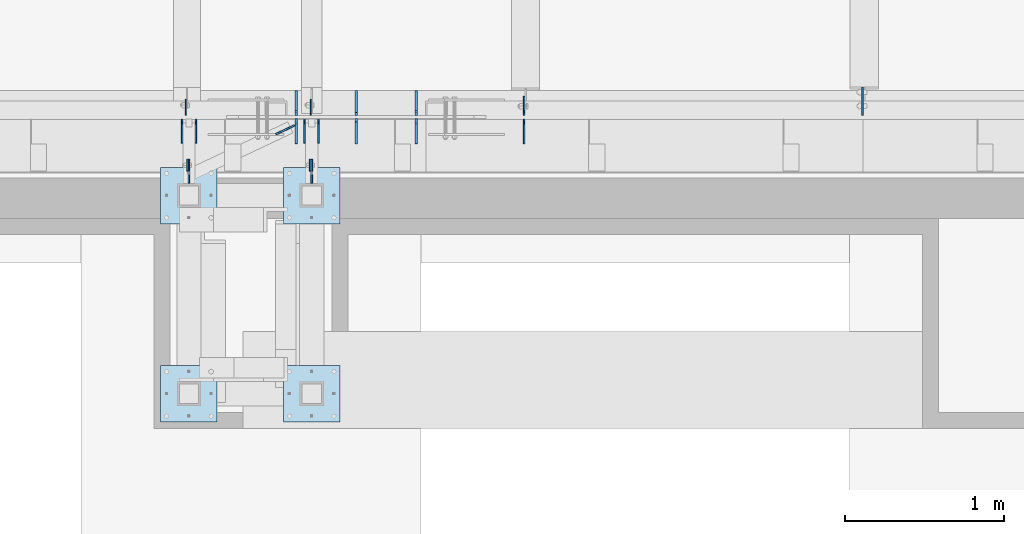
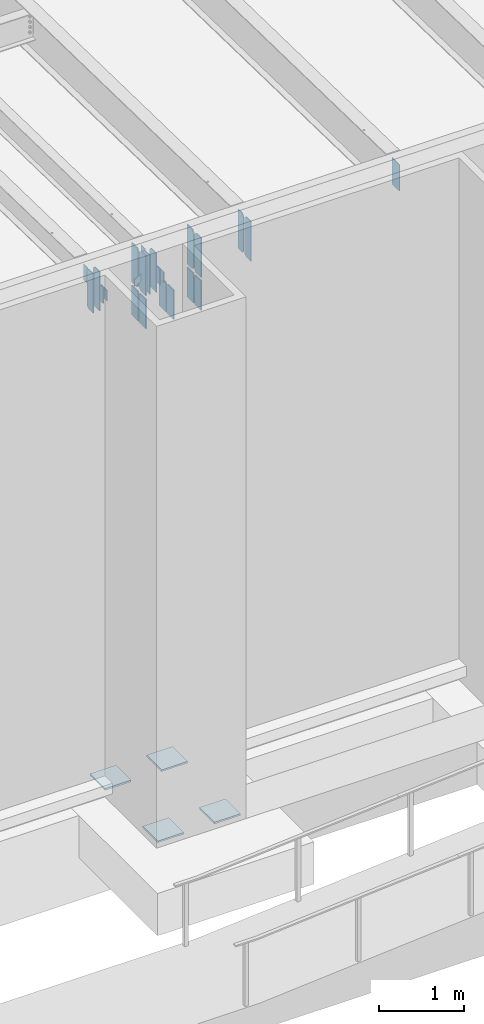
# One storey, part 1428 of 1763: 28 plates, 4 elements without a shape of their own.
"""IFC2X3 building model written with IfcOpenShell, lengths in millimetres."""

from ifc_helpers import new_model, si_unit, frame, origin_with_axes, place, context, subcontext, project, spatial, faceted_brep, material, type_object, element, aggregate, save


model = new_model("IFC2X3")

# Units and contexts
model_context = context("Model", 3, precision=1e-05, world=origin_with_axes())
body_context = subcontext(model_context, "Body", "Model", "MODEL_VIEW")
ifc_project = project(units=[si_unit("LENGTHUNIT", "METRE", prefix="MILLI"), si_unit("AREAUNIT", "SQUARE_METRE"), si_unit("VOLUMEUNIT", "CUBIC_METRE"), si_unit("MASSUNIT", "GRAM", prefix="KILO"), si_unit("TIMEUNIT", "SECOND"), si_unit("PLANEANGLEUNIT", "RADIAN"), si_unit("SOLIDANGLEUNIT", "STERADIAN"), si_unit("THERMODYNAMICTEMPERATUREUNIT", "DEGREE_CELSIUS"), si_unit("LUMINOUSINTENSITYUNIT", "LUMEN")], contexts=[model_context])

# Site, building, storey
site_placement = place(None, origin_with_axes())
site = spatial("IfcSite", under=ifc_project, at=site_placement, CompositionType="ELEMENT")
building_placement = place(site_placement, origin_with_axes())
building = spatial("IfcBuilding", under=site, at=building_placement, Name="Undefined", CompositionType="ELEMENT")
storey_placement = place(building_placement, origin_with_axes())
storey = spatial("IfcBuildingStorey", under=building, at=storey_placement, Name="Undefined", CompositionType="ELEMENT", Elevation=0.0)

# Assembly, plate
assembly_1_placement = place(storey_placement, origin_with_axes())
assembly_1 = element("IfcElementAssembly", 1, at=assembly_1_placement, inside=storey, Name="BEAM", AssemblyPlace="NOTDEFINED", PredefinedType="RIGID_FRAME")
ifc_material = material(Name="STEEL/A36")
plate_type_1 = type_object("IfcPlateType", PredefinedType="NOTDEFINED")
plate_1_placement = place(assembly_1_placement, frame((-80993.6873745708, -14055.7242553587, 11823.7), z_axis=(0.0, 0.0, 1.0), x_axis=(0.0, 1.0, 0.0)))
plate_1 = element("IfcPlate", 2, at=plate_1_placement, type_object=plate_type_1, material=ifc_material, Name="PLATE", context=body_context, shape_type="Brep", body=[
    faceted_brep([(0.0, -4.76249999999982, 0.0), (-2.83762346953154e-10, -4.7624999996915, 228.600006103516), (-2.83762346953154e-10, 4.76250000028813, 228.600006103517), (0.0, 4.76249999999982, 0.0), (76.1999969480166, -4.76249999961874, 228.600006103516), (76.1999969480166, 4.76250000036089, 228.600006103517), (76.1999969482931, -4.76249999991705, 0.0), (76.1999969482931, 4.76250000006257, 1.81898940354586e-12)], [[[0, 1, 2, 3]], [[1, 4, 5, 2]], [[4, 6, 7, 5]], [[6, 0, 3, 7]], [[5, 7, 3, 2]], [[6, 4, 1, 0]]]),
])
aggregate(assembly_1, [plate_1])

assembly_2_placement = place(storey_placement, origin_with_axes())
assembly_2 = element("IfcElementAssembly", 3, at=assembly_2_placement, inside=storey, Name="BEAM", AssemblyPlace="NOTDEFINED", PredefinedType="RIGID_FRAME")
plate_2_placement = place(assembly_2_placement, frame((-80222.1623745725, -14055.7242553603, 11823.7), z_axis=(0.0, 0.0, 1.0), x_axis=(0.0, 1.0, 0.0)))
plate_2 = element("IfcPlate", 4, at=plate_2_placement, type_object=plate_type_1, material=ifc_material, Name="PLATE", context=body_context, shape_type="Brep", body=[
    faceted_brep([(0.0, -4.76249999999982, 0.0), (-2.83762346953154e-10, -4.7624999996915, 228.600006103516), (-2.83762346953154e-10, 4.76250000028813, 228.600006103517), (0.0, 4.76249999999982, 0.0), (76.1999969480166, -4.76249999961874, 228.600006103516), (76.1999969480166, 4.76250000036089, 228.600006103517), (76.1999969482931, -4.76249999991705, 0.0), (76.1999969482931, 4.76250000006257, 1.81898940354586e-12)], [[[0, 1, 2, 3]], [[1, 4, 5, 2]], [[4, 6, 7, 5]], [[6, 0, 3, 7]], [[5, 7, 3, 2]], [[6, 4, 1, 0]]]),
])
aggregate(assembly_2, [plate_2])

assembly_3_placement = place(storey_placement, origin_with_axes())
assembly_3 = element("IfcElementAssembly", 5, at=assembly_3_placement, inside=storey, Name="BEAM", AssemblyPlace="NOTDEFINED", PredefinedType="RIGID_FRAME")
plate_type_2 = type_object("IfcPlateType", PredefinedType="NOTDEFINED")
plate_3_placement = place(assembly_3_placement, frame((-78879.591345043, -13704.0935686171, 11590.3375), z_axis=(0.0, 0.0, 1.0), x_axis=(0.0, 1.0, 0.0)))
plate_3 = element("IfcPlate", 6, at=plate_3_placement, type_object=plate_type_2, material=ifc_material, Name="PLATE", context=body_context, shape_type="Brep", body=[
    faceted_brep([(0.0, -4.76250000000073, 31.75), (0.0, -4.76250000000073, 538.162475585938), (0.0, 4.76250000000073, 538.162475585938), (0.0, 4.76250000000073, 31.75), (31.75, -4.76250000000073, 569.912475585938), (31.75, 4.76250000000073, 569.912475585938), (120.650001525879, -4.76249999999709, 569.912475585938), (120.650001525879, 4.76249999999709, 569.912475585938), (120.650001525879, -4.76249999999709, 0.0), (120.650001525879, 4.76249999999709, 0.0), (31.75, -4.76250000000073, 0.0), (31.75, 4.76250000000073, 0.0)], [[[0, 1, 2, 3]], [[1, 4, 5, 2]], [[4, 6, 7, 5]], [[6, 8, 9, 7]], [[8, 10, 11, 9]], [[10, 0, 3, 11]], [[5, 7, 9, 11, 3, 2]], [[10, 8, 6, 4, 1, 0]]]),
])

# Assembly, plates
assembly_4_placement = place(storey_placement, origin_with_axes())
assembly_4 = element("IfcElementAssembly", 7, at=assembly_4_placement, inside=storey, Name="FRAME", AssemblyPlace="NOTDEFINED", PredefinedType="RIGID_FRAME")
plate_type_3 = type_object("IfcPlateType", PredefinedType="NOTDEFINED")
plate_4_placement = place(assembly_4_placement, frame((-80212.6370815854, -13979.5242583629, 12052.3000061035), z_axis=(0.0, 0.0, -1.0), x_axis=(0.0, -1.0, 0.0)))
plate_4 = element("IfcPlate", 8, at=plate_4_placement, type_object=plate_type_3, material=ifc_material, Name="PLATE", context=body_context, shape_type="Brep", body=[
    faceted_brep([(0.0, -4.76249999999982, 0.0), (-3.05175672110636e-06, -4.7625000002663, 152.399993896484), (-3.05175490211695e-06, 4.76249999972788, 152.399993896484), (0.0, 4.76249999999982, 0.0), (152.400009155272, -4.76249999975698, 152.399993896484), (152.400009155273, 4.76250000024447, 152.399993896484), (152.400009155272, -4.76249999948777, 5.45696821063757e-12), (152.400009155273, 4.76250000051368, 3.63797880709171e-12)], [[[0, 1, 2, 3]], [[1, 4, 5, 2]], [[4, 6, 7, 5]], [[6, 0, 3, 7]], [[5, 7, 3, 2]], [[6, 4, 1, 0]]]),
])
plate_5_placement = place(assembly_4_placement, frame((-80984.1620815855, -13979.5242583629, 12052.3000061035), z_axis=(0.0, 0.0, -1.0), x_axis=(0.0, -1.0, 0.0)))
plate_5 = element("IfcPlate", 9, at=plate_5_placement, type_object=plate_type_3, material=ifc_material, Name="PLATE", context=body_context, shape_type="Brep", body=[
    faceted_brep([(0.0, -4.76249999999982, 0.0), (-3.05175672110636e-06, -4.7625000002663, 152.399993896484), (-3.05175490211695e-06, 4.76249999972788, 152.399993896484), (0.0, 4.76249999999982, 0.0), (152.400009155272, -4.76249999975698, 152.399993896484), (152.400009155273, 4.76250000024447, 152.399993896484), (152.400009155272, -4.76249999948777, 5.45696821063757e-12), (152.400009155273, 4.76250000051368, 3.63797880709171e-12)], [[[0, 1, 2, 3]], [[1, 4, 5, 2]], [[4, 6, 7, 5]], [[6, 0, 3, 7]], [[5, 7, 3, 2]], [[6, 4, 1, 0]]]),
])

# Plate
plate_6_placement = place(assembly_3_placement, frame((-80939.7128728711, -13880.3060686171, 11590.3375), z_axis=(0.0, 0.0, 1.0), x_axis=(0.0, 1.0, 0.0)))
plate_6 = element("IfcPlate", 10, at=plate_6_placement, type_object=plate_type_3, material=ifc_material, Name="PLATE", context=body_context, shape_type="Brep", body=[
    faceted_brep([(0.0, -4.76249999999982, 0.0), (0.0, -4.76250000012806, 568.325012206604), (0.0, 4.7624999999025, 568.325012206606), (0.0, 4.76249999999982, 0.0), (120.649993896484, -4.76250000000073, 568.325012207031), (120.649993896484, 4.76250000000073, 568.325012207031), (152.399993896484, -4.76250000000073, 536.575012207031), (152.399993896484, 4.76250000000073, 536.575012207031), (152.399993896484, -4.76250000000073, 31.75), (152.399993896484, 4.76250000000073, 31.75), (120.650001525879, -4.76249999999709, 0.0), (120.650001525879, 4.76249999999709, 0.0)], [[[0, 1, 2, 3]], [[1, 4, 5, 2]], [[4, 6, 7, 5]], [[6, 8, 9, 7]], [[8, 10, 11, 9]], [[10, 0, 3, 11]], [[5, 7, 9, 11, 3, 2]], [[10, 8, 6, 4, 1, 0]]]),
])

plate_7_placement = place(assembly_3_placement, frame((-81027.0248728712, -13880.3060686171, 11590.3375), z_axis=(0.0, 0.0, 1.0), x_axis=(0.0, 1.0, 0.0)))
plate_7 = element("IfcPlate", 11, at=plate_7_placement, type_object=plate_type_3, material=ifc_material, Name="PLATE", context=body_context, shape_type="Brep", body=[
    faceted_brep([(0.0, -4.76249999999982, 0.0), (0.0, -4.76250000012806, 568.325012206604), (0.0, 4.7624999999025, 568.325012206606), (0.0, 4.76249999999982, 0.0), (120.649993896484, -4.76250000000073, 568.325012207031), (120.649993896484, 4.76250000000073, 568.325012207031), (152.399993896484, -4.76250000000073, 536.575012207031), (152.399993896484, 4.76250000000073, 536.575012207031), (152.399993896484, -4.76250000000073, 31.75), (152.399993896484, 4.76250000000073, 31.75), (120.650001525879, -4.76249999999709, 0.0), (120.650001525879, 4.76249999999709, 0.0)], [[[0, 1, 2, 3]], [[1, 4, 5, 2]], [[4, 6, 7, 5]], [[6, 8, 9, 7]], [[8, 10, 11, 9]], [[10, 0, 3, 11]], [[5, 7, 9, 11, 3, 2]], [[10, 8, 6, 4, 1, 0]]]),
])

plate_8_placement = place(assembly_3_placement, frame((-80169.7748728729, -13880.3060686171, 11590.3375), z_axis=(0.0, 0.0, 1.0), x_axis=(0.0, 1.0, 0.0)))
plate_8 = element("IfcPlate", 12, at=plate_8_placement, type_object=plate_type_3, material=ifc_material, Name="PLATE", context=body_context, shape_type="Brep", body=[
    faceted_brep([(0.0, -4.76249999999982, 0.0), (0.0, -4.76250000012806, 568.325012206604), (0.0, 4.7624999999025, 568.325012206606), (0.0, 4.76249999999982, 0.0), (120.649993896484, -4.76250000000073, 568.325012207031), (120.649993896484, 4.76250000000073, 568.325012207031), (152.399993896484, -4.76250000000073, 536.575012207031), (152.399993896484, 4.76250000000073, 536.575012207031), (152.399993896484, -4.76250000000073, 31.75), (152.399993896484, 4.76250000000073, 31.75), (120.650001525879, -4.76249999999709, 0.0), (120.650001525879, 4.76249999999709, 0.0)], [[[0, 1, 2, 3]], [[1, 4, 5, 2]], [[4, 6, 7, 5]], [[6, 8, 9, 7]], [[8, 10, 11, 9]], [[10, 0, 3, 11]], [[5, 7, 9, 11, 3, 2]], [[10, 8, 6, 4, 1, 0]]]),
])

plate_9_placement = place(assembly_3_placement, frame((-80257.0868728729, -13880.3060686171, 11590.3375), z_axis=(0.0, 0.0, 1.0), x_axis=(0.0, 1.0, 0.0)))
plate_9 = element("IfcPlate", 13, at=plate_9_placement, type_object=plate_type_3, material=ifc_material, Name="PLATE", context=body_context, shape_type="Brep", body=[
    faceted_brep([(0.0, -4.76249999999982, 0.0), (0.0, -4.76250000012806, 568.325012206604), (0.0, 4.7624999999025, 568.325012206606), (0.0, 4.76249999999982, 0.0), (120.649993896484, -4.76250000000073, 568.325012207031), (120.649993896484, 4.76250000000073, 568.325012207031), (152.399993896484, -4.76250000000073, 536.575012207031), (152.399993896484, 4.76250000000073, 536.575012207031), (152.399993896484, -4.76250000000073, 31.75), (152.399993896484, 4.76250000000073, 31.75), (120.650001525879, -4.76249999999709, 0.0), (120.650001525879, 4.76249999999709, 0.0)], [[[0, 1, 2, 3]], [[1, 4, 5, 2]], [[4, 6, 7, 5]], [[6, 8, 9, 7]], [[8, 10, 11, 9]], [[10, 0, 3, 11]], [[5, 7, 9, 11, 3, 2]], [[10, 8, 6, 4, 1, 0]]]),
])

plate_type_4 = type_object("IfcPlateType", PredefinedType="NOTDEFINED")
plate_10_placement = place(assembly_3_placement, frame((-80218.9871775587, -13704.0935686171, 12126.8985850735), z_axis=(0.0, 1.0, 0.0), x_axis=(0.0, 0.0, -1.0)))
plate_10 = element("IfcPlate", 14, at=plate_10_placement, type_object=plate_type_4, material=ifc_material, Name="PLATE", context=body_context, shape_type="Brep", body=[
    faceted_brep([(1.81898940354586e-12, -3.17500000000291, 0.0), (0.0, -3.17499999999927, 101.599998474121), (0.0, 3.17499999999927, 101.599998474121), (-1.81898940354586e-12, 3.17499999997381, 0.0), (228.600006103516, -3.17499999999927, 101.599998474121), (228.600006103516, 3.17499999999927, 101.599998474121), (228.600006103516, -3.17500000001019, -7.27595761418343e-12), (228.600006103516, 3.17499999999563, -7.27595761418343e-12)], [[[0, 1, 2, 3]], [[1, 4, 5, 2]], [[4, 6, 7, 5]], [[6, 0, 3, 7]], [[5, 7, 3, 2]], [[6, 4, 1, 0]]]),
])

plate_11_placement = place(assembly_3_placement, frame((-81002.7587022698, -13704.0935686171, 12126.8985850736), z_axis=(0.0, 1.0, 0.0), x_axis=(0.0, 0.0, -1.0)))
plate_11 = element("IfcPlate", 15, at=plate_11_placement, type_object=plate_type_4, material=ifc_material, Name="PLATE", context=body_context, shape_type="Brep", body=[
    faceted_brep([(1.81898940354586e-12, -3.17500000000291, 0.0), (0.0, -3.17499999999927, 101.599998474121), (0.0, 3.17499999999927, 101.599998474121), (-1.81898940354586e-12, 3.17499999997381, 0.0), (228.600006103516, -3.17499999999927, 101.599998474121), (228.600006103516, 3.17499999999927, 101.599998474121), (228.600006103516, -3.17500000001019, -7.27595761418343e-12), (228.600006103516, 3.17499999999563, -7.27595761418343e-12)], [[[0, 1, 2, 3]], [[1, 4, 5, 2]], [[4, 6, 7, 5]], [[6, 0, 3, 7]], [[5, 7, 3, 2]], [[6, 4, 1, 0]]]),
])

plate_type_5 = type_object("IfcPlateType", PredefinedType="NOTDEFINED")
plate_12_placement = place(assembly_4_placement, frame((-80390.4370783858, -14030.3242675181, 5079.99999999999), z_axis=(1.0, 0.0, 0.0), x_axis=(0.0, -1.0, 0.0)))
plate_12 = element("IfcPlate", 16, at=plate_12_placement, type_object=plate_type_5, material=ifc_material, Name="PLATE", context=body_context, shape_type="Brep", body=[
    faceted_brep([(0.0, -12.6999999999971, -1.81898940354586e-12), (0.0, -12.6999999999998, 355.600006103516), (0.0, 12.6999999999998, 355.600006103516), (0.0, 12.6999999999971, -1.81898940354586e-12), (355.600006103516, -12.6999999999998, 355.600006103516), (355.600006103516, 12.6999999999998, 355.600006103516), (355.600006103516, -12.6999999999998, 0.0), (355.600006103516, 12.6999999999998, 0.0)], [[[0, 1, 2, 3]], [[1, 4, 5, 2]], [[4, 6, 7, 5]], [[6, 0, 3, 7]], [[5, 7, 3, 2]], [[6, 4, 1, 0]]]),
])

plate_13_placement = place(assembly_4_placement, frame((-81161.9622736984, -14030.3242675181, 5080.0), z_axis=(1.0, 0.0, 0.0), x_axis=(0.0, -1.0, 0.0)))
plate_13 = element("IfcPlate", 17, at=plate_13_placement, type_object=plate_type_5, material=ifc_material, Name="PLATE", context=body_context, shape_type="Brep", body=[
    faceted_brep([(0.0, -12.6999999999971, -1.81898940354586e-12), (0.0, -12.6999999999998, 355.600006103516), (0.0, 12.6999999999998, 355.600006103516), (0.0, 12.6999999999971, -1.81898940354586e-12), (355.600006103516, -12.6999999999998, 355.600006103516), (355.600006103516, 12.6999999999998, 355.600006103516), (355.600006103516, -12.6999999999998, 0.0), (355.600006103516, 12.6999999999998, 0.0)], [[[0, 1, 2, 3]], [[1, 4, 5, 2]], [[4, 6, 7, 5]], [[6, 0, 3, 7]], [[5, 7, 3, 2]], [[6, 4, 1, 0]]]),
])

plate_14_placement = place(assembly_4_placement, frame((-80390.4370783858, -15274.9242675181, 5080.0), z_axis=(1.0, 0.0, 0.0), x_axis=(0.0, -1.0, 0.0)))
plate_14 = element("IfcPlate", 18, at=plate_14_placement, type_object=plate_type_5, material=ifc_material, Name="PLATE", context=body_context, shape_type="Brep", body=[
    faceted_brep([(0.0, -12.6999999999971, -1.81898940354586e-12), (0.0, -12.6999999999998, 355.600006103516), (0.0, 12.6999999999998, 355.600006103516), (0.0, 12.6999999999971, -1.81898940354586e-12), (355.600006103516, -12.6999999999998, 355.600006103516), (355.600006103516, 12.6999999999998, 355.600006103516), (355.600006103516, -12.6999999999998, 0.0), (355.600006103516, 12.6999999999998, 0.0)], [[[0, 1, 2, 3]], [[1, 4, 5, 2]], [[4, 6, 7, 5]], [[6, 0, 3, 7]], [[5, 7, 3, 2]], [[6, 4, 1, 0]]]),
])

plate_15_placement = place(assembly_4_placement, frame((-81161.9622736984, -15274.9242675181, 5080.0), z_axis=(1.0, 0.0, 0.0), x_axis=(0.0, -1.0, 0.0)))
plate_15 = element("IfcPlate", 19, at=plate_15_placement, type_object=plate_type_5, material=ifc_material, Name="PLATE", context=body_context, shape_type="Brep", body=[
    faceted_brep([(0.0, -12.6999999999971, -1.81898940354586e-12), (0.0, -12.6999999999998, 355.600006103516), (0.0, 12.6999999999998, 355.600006103516), (0.0, 12.6999999999971, -1.81898940354586e-12), (355.600006103516, -12.6999999999998, 355.600006103516), (355.600006103516, 12.6999999999998, 355.600006103516), (355.600006103516, -12.6999999999998, 0.0), (355.600006103516, 12.6999999999998, 0.0)], [[[0, 1, 2, 3]], [[1, 4, 5, 2]], [[4, 6, 7, 5]], [[6, 0, 3, 7]], [[5, 7, 3, 2]], [[6, 4, 1, 0]]]),
])

aggregate(assembly_4, [plate_12, plate_13, plate_14, plate_15, plate_4, plate_5])

plate_type_6 = type_object("IfcPlateType", PredefinedType="NOTDEFINED")
plate_16_placement = place(assembly_3_placement, frame((-80438.5891240201, -13822.9585796581, 11734.8), z_axis=(0.0, 0.0, 1.0), x_axis=(0.903823842179388, 0.427904735084911, 0.0)))
plate_16 = element("IfcPlate", 20, at=plate_16_placement, type_object=plate_type_6, material=ifc_material, Name="PLATE", context=body_context, shape_type="Brep", body=[
    faceted_brep([(0.0, -4.76249999999982, 0.0), (1.45519152283669e-11, -4.76250000000448, 101.60001373291), (0.0, 4.76250000000243, 101.60001373291), (0.0, 4.76249999999982, 0.0), (131.426315307472, -4.76249999996435, 101.60001373291), (131.426315307457, 4.76250000005166, 101.60001373291), (131.426315307472, -4.76249999996435, 0.0), (131.426315307457, 4.76250000005166, 0.0)], [[[0, 1, 2, 3]], [[1, 4, 5, 2]], [[4, 6, 7, 5]], [[6, 0, 3, 7]], [[5, 7, 3, 2]], [[6, 4, 1, 0]]]),
])

plate_type_7 = type_object("IfcPlateType", PredefinedType="NOTDEFINED")
plate_17_placement = place(assembly_3_placement, frame((-79556.6474709374, -13880.3060686171, 11590.3375), z_axis=(0.0, 0.0, 1.0), x_axis=(0.0, 1.0, 0.0)))
plate_17 = element("IfcPlate", 21, at=plate_17_placement, type_object=plate_type_7, material=ifc_material, Name="PLATE", context=body_context, shape_type="Brep", body=[
    faceted_brep([(-7.27595761418343e-12, -7.9375, 0.0), (0.0, -7.9375, 568.325012207031), (0.0, 7.9375, 568.325012207031), (-7.27595761418343e-12, 7.9375, 0.0), (120.649993896484, -7.9375, 568.325012207031), (120.649993896484, 7.9375, 568.325012207031), (152.399993896484, -7.9375, 536.575012207031), (152.399993896484, 7.9375, 536.575012207031), (152.399993896484, -7.9375, 31.75), (152.399993896484, 7.9375, 31.75), (120.649993896484, -7.9375, 0.0), (120.649993896484, 7.9375, 0.0)], [[[0, 1, 2, 3]], [[1, 4, 5, 2]], [[4, 6, 7, 5]], [[6, 8, 9, 7]], [[8, 10, 11, 9]], [[10, 0, 3, 11]], [[5, 7, 9, 11, 3, 2]], [[10, 8, 6, 4, 1, 0]]]),
])

plate_18_placement = place(assembly_3_placement, frame((-79556.6474709374, -13704.0935686171, 11590.3375), z_axis=(0.0, 0.0, 1.0), x_axis=(0.0, 1.0, 0.0)))
plate_18 = element("IfcPlate", 22, at=plate_18_placement, type_object=plate_type_7, material=ifc_material, Name="PLATE", context=body_context, shape_type="Brep", body=[
    faceted_brep([(0.0, -7.9375, 31.75), (0.0, -7.9375, 536.575012207031), (0.0, 7.9375, 536.575012207031), (0.0, 7.9375, 31.75), (31.75, -7.9375, 568.325012207031), (31.75, 7.9375, 568.325012207031), (152.399993896484, -7.9375, 568.325012207031), (152.399993896484, 7.9375, 568.325012207031), (152.399993896484, -7.9375, -1.81898940354586e-12), (152.399993896484, 7.9375, -1.81898940354586e-12), (31.75, -7.9375, 0.0), (31.75, 7.9375, 0.0)], [[[0, 1, 2, 3]], [[1, 4, 5, 2]], [[4, 6, 7, 5]], [[6, 8, 9, 7]], [[8, 10, 11, 9]], [[10, 0, 3, 11]], [[5, 7, 9, 11, 3, 2]], [[10, 8, 6, 4, 1, 0]]]),
])

plate_19_placement = place(assembly_3_placement, frame((-80309.8270797902, -13880.3060686171, 11590.3375), z_axis=(0.0, 0.0, 1.0), x_axis=(0.0, 1.0, 0.0)))
plate_19 = element("IfcPlate", 23, at=plate_19_placement, type_object=plate_type_7, material=ifc_material, Name="PLATE", context=body_context, shape_type="Brep", body=[
    faceted_brep([(-7.27595761418343e-12, -7.9375, 0.0), (0.0, -7.9375, 568.325012207031), (0.0, 7.9375, 568.325012207031), (-7.27595761418343e-12, 7.9375, 0.0), (120.649993896484, -7.9375, 568.325012207031), (120.649993896484, 7.9375, 568.325012207031), (152.399993896484, -7.9375, 536.575012207031), (152.399993896484, 7.9375, 536.575012207031), (152.399993896484, -7.9375, 31.75), (152.399993896484, 7.9375, 31.75), (120.649993896484, -7.9375, 0.0), (120.649993896484, 7.9375, 0.0)], [[[0, 1, 2, 3]], [[1, 4, 5, 2]], [[4, 6, 7, 5]], [[6, 8, 9, 7]], [[8, 10, 11, 9]], [[10, 0, 3, 11]], [[5, 7, 9, 11, 3, 2]], [[10, 8, 6, 4, 1, 0]]]),
])

plate_20_placement = place(assembly_3_placement, frame((-80309.8270797902, -13704.0935686171, 11590.3375), z_axis=(0.0, 0.0, 1.0), x_axis=(0.0, 1.0, 0.0)))
plate_20 = element("IfcPlate", 24, at=plate_20_placement, type_object=plate_type_7, material=ifc_material, Name="PLATE", context=body_context, shape_type="Brep", body=[
    faceted_brep([(0.0, -7.9375, 31.75), (0.0, -7.9375, 536.575012207031), (0.0, 7.9375, 536.575012207031), (0.0, 7.9375, 31.75), (31.75, -7.9375, 568.325012207031), (31.75, 7.9375, 568.325012207031), (152.399993896484, -7.9375, 568.325012207031), (152.399993896484, 7.9375, 568.325012207031), (152.399993896484, -7.9375, -1.81898940354586e-12), (152.399993896484, 7.9375, -1.81898940354586e-12), (31.75, -7.9375, 0.0), (31.75, 7.9375, 0.0)], [[[0, 1, 2, 3]], [[1, 4, 5, 2]], [[4, 6, 7, 5]], [[6, 8, 9, 7]], [[8, 10, 11, 9]], [[10, 0, 3, 11]], [[5, 7, 9, 11, 3, 2]], [[10, 8, 6, 4, 1, 0]]]),
])

plate_type_8 = type_object("IfcPlateType", PredefinedType="NOTDEFINED")
plate_21_placement = place(assembly_3_placement, frame((-76753.2479879841, -13704.0935686171, 12126.8985850736), z_axis=(0.0, 1.0, 0.0), x_axis=(0.0, 0.0, -1.0)))
plate_21 = element("IfcPlate", 25, at=plate_21_placement, type_object=plate_type_8, material=ifc_material, Name="PLATE", context=body_context, shape_type="Brep", body=[
    faceted_brep([(0.0, -4.76249999999982, 0.0), (0.0, -4.76249999999709, 177.800003051758), (0.0, 4.76249999999709, 177.800003051758), (0.0, 4.76249999999982, 0.0), (381.0, -4.76249999999709, 177.800003051758), (381.0, 4.76249999999709, 177.800003051758), (381.0, -4.76250000000073, 0.0), (381.0, 4.76250000000073, 0.0)], [[[0, 1, 2, 3]], [[1, 4, 5, 2]], [[4, 6, 7, 5]], [[6, 0, 3, 7]], [[5, 7, 3, 2]], [[6, 4, 1, 0]]]),
])

plate_type_9 = type_object("IfcPlateType", PredefinedType="NOTDEFINED")
plate_22_placement = place(assembly_3_placement, frame((-79556.6469709404, -13725.5249999996, 11544.2999996961), z_axis=(0.0, 0.0, -1.0), x_axis=(0.0, -1.0, 0.0)))
plate_22 = element("IfcPlate", 26, at=plate_22_placement, type_object=plate_type_9, material=ifc_material, Name="PLATE", context=body_context, shape_type="Brep", body=[
    faceted_brep([(-3.27418092638254e-10, -7.9375, 19.0499992370605), (-9.10017479327507e-06, -7.9375, 424.804992675779), (-9.10017479327507e-06, 7.9375, 424.804992675779), (-3.27418092638254e-10, 7.9375, 19.0499992370605), (157.162307739356, -7.9375, 424.804992675743), (157.162307739356, 7.9375, 424.804992675743), (157.162322998045, -7.9375, -1.07320374809206e-10), (157.162322998045, 7.9375, -1.07320374809206e-10), (19.0499815529183, -7.9375, 0.0), (19.0499815529183, 7.9375, 0.0)], [[[0, 1, 2, 3]], [[1, 4, 5, 2]], [[4, 6, 7, 5]], [[6, 8, 9, 7]], [[8, 0, 3, 9]], [[5, 7, 9, 3, 2]], [[8, 6, 4, 1, 0]]]),
])

plate_23_placement = place(assembly_3_placement, frame((-79556.6469709375, -13549.3123186168, 11544.3), z_axis=(0.0, 0.0, -1.0), x_axis=(0.0, -1.0, 0.0)))
plate_23 = element("IfcPlate", 27, at=plate_23_placement, type_object=plate_type_9, material=ifc_material, Name="PLATE", context=body_context, shape_type="Brep", body=[
    faceted_brep([(-7.27595761418343e-12, -7.9375, 0.0), (-9.10017479327507e-06, -7.9375, 424.804992675779), (-9.10017479327507e-06, 7.9375, 424.804992675779), (-7.27595761418343e-12, 7.9375, 0.0), (157.162673950006, -7.9375, 424.80499267585), (157.162673950006, 7.9375, 424.80499267585), (157.162673950188, -7.9375, 19.0499992370023), (157.162673950188, 7.9375, 19.0499992370023), (138.112674713135, -7.9375, -5.0931703299284e-11), (138.112674713135, 7.9375, -5.0931703299284e-11)], [[[0, 1, 2, 3]], [[1, 4, 5, 2]], [[4, 6, 7, 5]], [[6, 8, 9, 7]], [[8, 0, 3, 9]], [[5, 7, 9, 3, 2]], [[8, 6, 4, 1, 0]]]),
])

plate_24_placement = place(assembly_3_placement, frame((-80309.8275797902, -13725.5249999997, 11544.2999999932), z_axis=(0.0, 0.0, -1.0), x_axis=(0.0, -1.0, 0.0)))
plate_24 = element("IfcPlate", 28, at=plate_24_placement, type_object=plate_type_9, material=ifc_material, Name="PLATE", context=body_context, shape_type="Brep", body=[
    faceted_brep([(-3.27418092638254e-10, -7.9375, 19.0499992370605), (-9.10017479327507e-06, -7.9375, 424.804992675779), (-9.10017479327507e-06, 7.9375, 424.804992675779), (-3.27418092638254e-10, 7.9375, 19.0499992370605), (157.162307739356, -7.9375, 424.804992675743), (157.162307739356, 7.9375, 424.804992675743), (157.162322998045, -7.9375, -1.07320374809206e-10), (157.162322998045, 7.9375, -1.07320374809206e-10), (19.0499815529183, -7.9375, 0.0), (19.0499815529183, 7.9375, 0.0)], [[[0, 1, 2, 3]], [[1, 4, 5, 2]], [[4, 6, 7, 5]], [[6, 8, 9, 7]], [[8, 0, 3, 9]], [[5, 7, 9, 3, 2]], [[8, 6, 4, 1, 0]]]),
])

plate_25_placement = place(assembly_3_placement, frame((-79933.237453629, -13725.525, 11544.2999999907), z_axis=(0.0, 0.0, -1.0), x_axis=(0.0, -1.0, 0.0)))
plate_25 = element("IfcPlate", 29, at=plate_25_placement, type_object=plate_type_9, material=ifc_material, Name="PLATE", context=body_context, shape_type="Brep", body=[
    faceted_brep([(-3.27418092638254e-10, -7.9375, 19.0499992370605), (-9.10017479327507e-06, -7.9375, 424.804992675779), (-9.10017479327507e-06, 7.9375, 424.804992675779), (-3.27418092638254e-10, 7.9375, 19.0499992370605), (157.162307739356, -7.9375, 424.804992675743), (157.162307739356, 7.9375, 424.804992675743), (157.162322998045, -7.9375, -1.07320374809206e-10), (157.162322998045, 7.9375, -1.07320374809206e-10), (19.0499815529183, -7.9375, 0.0), (19.0499815529183, 7.9375, 0.0)], [[[0, 1, 2, 3]], [[1, 4, 5, 2]], [[4, 6, 7, 5]], [[6, 8, 9, 7]], [[8, 0, 3, 9]], [[5, 7, 9, 3, 2]], [[8, 6, 4, 1, 0]]]),
])

plate_26_placement = place(assembly_3_placement, frame((-80309.8275797902, -13549.3123186168, 11544.3000002217), z_axis=(0.0, 0.0, -1.0), x_axis=(0.0, -1.0, 0.0)))
plate_26 = element("IfcPlate", 30, at=plate_26_placement, type_object=plate_type_9, material=ifc_material, Name="PLATE", context=body_context, shape_type="Brep", body=[
    faceted_brep([(-7.27595761418343e-12, -7.9375, 0.0), (-9.10017479327507e-06, -7.9375, 424.804992675779), (-9.10017479327507e-06, 7.9375, 424.804992675779), (-7.27595761418343e-12, 7.9375, 0.0), (157.162673950006, -7.9375, 424.80499267585), (157.162673950006, 7.9375, 424.80499267585), (157.162673950188, -7.9375, 19.0499992370023), (157.162673950188, 7.9375, 19.0499992370023), (138.112674713135, -7.9375, -5.0931703299284e-11), (138.112674713135, 7.9375, -5.0931703299284e-11)], [[[0, 1, 2, 3]], [[1, 4, 5, 2]], [[4, 6, 7, 5]], [[6, 8, 9, 7]], [[8, 0, 3, 9]], [[5, 7, 9, 3, 2]], [[8, 6, 4, 1, 0]]]),
])

plate_27_placement = place(assembly_3_placement, frame((-79933.237453629, -13549.312318617, 11544.3000002192), z_axis=(0.0, 0.0, -1.0), x_axis=(0.0, -1.0, 0.0)))
plate_27 = element("IfcPlate", 31, at=plate_27_placement, type_object=plate_type_9, material=ifc_material, Name="PLATE", context=body_context, shape_type="Brep", body=[
    faceted_brep([(-7.27595761418343e-12, -7.9375, 0.0), (-9.10017479327507e-06, -7.9375, 424.804992675779), (-9.10017479327507e-06, 7.9375, 424.804992675779), (-7.27595761418343e-12, 7.9375, 0.0), (157.162673950006, -7.9375, 424.80499267585), (157.162673950006, 7.9375, 424.80499267585), (157.162673950188, -7.9375, 19.0499992370023), (157.162673950188, 7.9375, 19.0499992370023), (138.112674713135, -7.9375, -5.0931703299284e-11), (138.112674713135, 7.9375, -5.0931703299284e-11)], [[[0, 1, 2, 3]], [[1, 4, 5, 2]], [[4, 6, 7, 5]], [[6, 8, 9, 7]], [[8, 0, 3, 9]], [[5, 7, 9, 3, 2]], [[8, 6, 4, 1, 0]]]),
])

plate_type_10 = type_object("IfcPlateType", PredefinedType="NOTDEFINED")
plate_28_placement = place(assembly_3_placement, frame((-78879.591345043, -13727.9060686171, 11588.75), z_axis=(0.0, 0.0, 1.0), x_axis=(0.0, -1.0, 0.0)))
plate_28 = element("IfcPlate", 32, at=plate_28_placement, type_object=plate_type_10, material=ifc_material, Name="PLATE", context=body_context, shape_type="Brep", body=[
    faceted_brep([(0.0, -4.76250000000073, 31.75), (0.0, -4.76250000000073, 539.75), (0.0, 4.76250000000073, 539.75), (0.0, 4.76250000000073, 31.75), (31.75, -4.76250000000073, 571.5), (31.75, 4.76250000000073, 571.5), (154.78125, -4.76250000000073, 571.5), (154.78125, 4.76250000000073, 571.5), (154.78125, -4.76250000000073, 0.0), (154.78125, 4.76250000000073, 0.0), (31.75, -4.76250000000073, 0.0), (31.75, 4.76250000000073, 0.0)], [[[0, 1, 2, 3]], [[1, 4, 5, 2]], [[4, 6, 7, 5]], [[6, 8, 9, 7]], [[8, 10, 11, 9]], [[10, 0, 3, 11]], [[5, 7, 9, 11, 3, 2]], [[10, 8, 6, 4, 1, 0]]]),
])

aggregate(assembly_3, [plate_16, plate_6, plate_7, plate_8, plate_9, plate_17, plate_18, plate_19, plate_20, plate_22, plate_23, plate_24, plate_25, plate_26, plate_27, plate_10, plate_11, plate_21, plate_28, plate_3])

save(model, "model.ifc")
